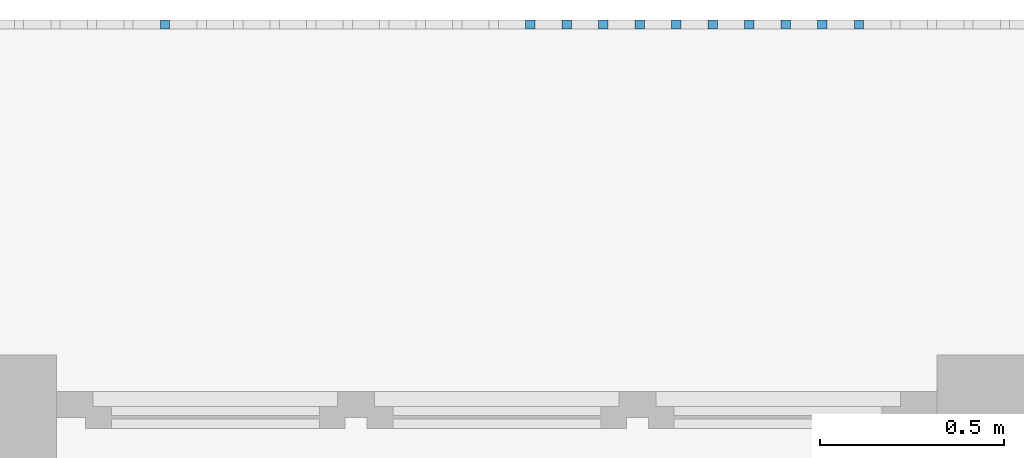
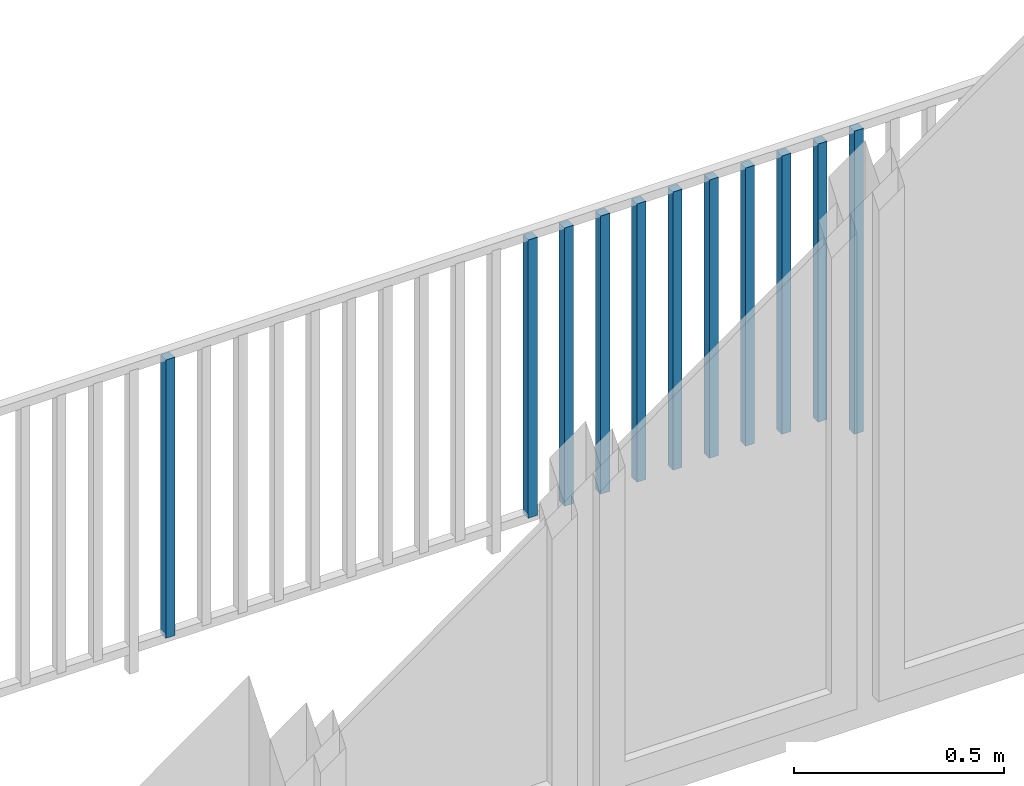
# One storey, part 51 of 54: 11 building element parts, 1 element without a shape of its own.
"""IFC4 building model written with IfcOpenShell, lengths in metres."""

from ifc_helpers import new_model, entity, si_unit, converted_unit, derived_unit, direction, frame, origin_with_axes, place, context, subcontext, project, spatial, polygons, material, type_object, element, aggregate, save


model = new_model("IFC4")

# Units and contexts
model_context = context("Model", 3, precision=1e-05, world=origin_with_axes(), true_north=direction((0.0, 1.0)))
body_context = subcontext(model_context, "Body", "Model", "MODEL_VIEW")
ifc_project = project(units=[si_unit("LENGTHUNIT", "METRE"), si_unit("AREAUNIT", "SQUARE_METRE"), si_unit("VOLUMEUNIT", "CUBIC_METRE"), converted_unit("PLANEANGLEUNIT", "DEGREE", entity("IfcPlaneAngleMeasure", 0.0174532925199), si_unit("PLANEANGLEUNIT", "RADIAN"), dimensions=[0, 0, 0, 0, 0, 0, 0]), converted_unit("TIMEUNIT", "Year", entity("IfcTimeMeasure", 31556926.0), si_unit("TIMEUNIT", "SECOND"), dimensions=[0, 0, 1, 0, 0, 0, 0]), si_unit("MASSUNIT", "GRAM", prefix="KILO"), si_unit("THERMODYNAMICTEMPERATUREUNIT", "DEGREE_CELSIUS"), si_unit("LUMINOUSINTENSITYUNIT", "LUMEN"), si_unit("ENERGYUNIT", "JOULE", prefix="MEGA"), derived_unit("THERMALCONDUCTANCEUNIT", [(si_unit("POWERUNIT", "WATT"), 1), (si_unit("LENGTHUNIT", "METRE"), -1), (si_unit("THERMODYNAMICTEMPERATUREUNIT", "KELVIN"), -1)]), derived_unit("SPECIFICHEATCAPACITYUNIT", [(si_unit("ENERGYUNIT", "JOULE"), 1), (si_unit("MASSUNIT", "GRAM", prefix="KILO"), -1), (si_unit("THERMODYNAMICTEMPERATUREUNIT", "KELVIN"), -1)]), derived_unit("MASSDENSITYUNIT", [(si_unit("MASSUNIT", "GRAM", prefix="KILO"), 1), (si_unit("VOLUMEUNIT", "CUBIC_METRE"), -1)])], contexts=[model_context])

# Site, building, storey, space
site_placement = place(None, origin_with_axes())
site = spatial("IfcSite", under=ifc_project, at=site_placement, CompositionType="ELEMENT")
building_placement = place(site_placement, origin_with_axes())
building = spatial("IfcBuilding", under=site, at=building_placement, CompositionType="ELEMENT")
storey_placement = place(building_placement, frame((0.0, 0.0, 9.18), z_axis=(0.0, 0.0, 1.0), x_axis=(1.0, 0.0, 0.0)))
storey = spatial("IfcBuildingStorey", under=building, at=storey_placement, Name="3. Geschoss", CompositionType="ELEMENT", Elevation=9.18)
space_placement = place(storey_placement, frame((10.2378006196, 9.82118769833, 0.0), z_axis=(0.0, 0.0, 1.0), x_axis=(-1.0, 0.0, 0.0)))
space = spatial("IfcSpace", under=storey, at=space_placement, CompositionType="ELEMENT", PredefinedType="EXTERNAL")

# Railing, building element parts
railing_type = type_object("IfcRailingType", PredefinedType="NOTDEFINED")
railing_placement = place(space_placement, frame((0.0, -7.06315681498e-08, 0.0), z_axis=(0.0, 0.0, 1.0), x_axis=(-1.0, 0.0, 0.0)))
railing = element("IfcRailing", 1, at=railing_placement, inside=space, type_object=railing_type, PredefinedType="NOTDEFINED")
ifc_material = material()
building_element_part_1_placement = place(railing_placement, origin_with_axes())
building_element_part_1 = element("IfcBuildingElementPart", 2, at=building_element_part_1_placement, material=ifc_material, PredefinedType="NOTDEFINED", context=body_context, shape_type="Tessellation", body=[
    polygons([(-6.97597826087, 0.0125, 0.0), (-6.97597826087, -0.0125, 0.0), (-6.97597826087, -0.0125, 0.88), (-6.97597826087, 0.0125, 0.88), (-6.95097826087, 0.0125, 0.0), (-6.95097826087, -0.0125, 0.0), (-6.95097826087, -0.0125, 0.88), (-6.95097826087, 0.0125, 0.88)], [[[1, 2, 3, 4]], [[1, 5, 6, 2]], [[2, 6, 7, 3]], [[4, 3, 7, 8]], [[5, 1, 4, 8]], [[6, 5, 8, 7]]], closed=True),
])
building_element_part_2_placement = place(railing_placement, origin_with_axes())
building_element_part_2 = element("IfcBuildingElementPart", 3, at=building_element_part_2_placement, material=ifc_material, PredefinedType="NOTDEFINED", context=body_context, shape_type="Tessellation", body=[
    polygons([(-7.07545652174, 0.0125, 0.07), (-7.07545652174, -0.0125, 0.07), (-7.07545652174, -0.0125, 0.8775), (-7.07545652174, 0.0125, 0.8775), (-7.05045652174, 0.0125, 0.07), (-7.05045652174, -0.0125, 0.07), (-7.05045652174, -0.0125, 0.8775), (-7.05045652174, 0.0125, 0.8775)], [[[1, 2, 3, 4]], [[1, 5, 6, 2]], [[2, 6, 7, 3]], [[4, 3, 7, 8]], [[5, 1, 4, 8]], [[6, 5, 8, 7]]], closed=True),
])
building_element_part_3_placement = place(railing_placement, origin_with_axes())
building_element_part_3 = element("IfcBuildingElementPart", 4, at=building_element_part_3_placement, material=ifc_material, PredefinedType="NOTDEFINED", context=body_context, shape_type="Tessellation", body=[
    polygons([(-7.17493478261, 0.0125, 0.07), (-7.17493478261, -0.0125, 0.07), (-7.17493478261, -0.0125, 0.8775), (-7.17493478261, 0.0125, 0.8775), (-7.14993478261, 0.0125, 0.07), (-7.14993478261, -0.0125, 0.07), (-7.14993478261, -0.0125, 0.8775), (-7.14993478261, 0.0125, 0.8775)], [[[1, 2, 3, 4]], [[1, 5, 6, 2]], [[2, 6, 7, 3]], [[4, 3, 7, 8]], [[5, 1, 4, 8]], [[6, 5, 8, 7]]], closed=True),
])
building_element_part_4_placement = place(railing_placement, origin_with_axes())
building_element_part_4 = element("IfcBuildingElementPart", 5, at=building_element_part_4_placement, material=ifc_material, PredefinedType="NOTDEFINED", context=body_context, shape_type="Tessellation", body=[
    polygons([(-7.27441304348, 0.0125, 0.07), (-7.27441304348, -0.0125, 0.07), (-7.27441304348, -0.0125, 0.8775), (-7.27441304348, 0.0125, 0.8775), (-7.24941304348, 0.0125, 0.07), (-7.24941304348, -0.0125, 0.07), (-7.24941304348, -0.0125, 0.8775), (-7.24941304348, 0.0125, 0.8775)], [[[1, 2, 3, 4]], [[1, 5, 6, 2]], [[2, 6, 7, 3]], [[4, 3, 7, 8]], [[5, 1, 4, 8]], [[6, 5, 8, 7]]], closed=True),
])
building_element_part_5_placement = place(railing_placement, origin_with_axes())
building_element_part_5 = element("IfcBuildingElementPart", 6, at=building_element_part_5_placement, material=ifc_material, PredefinedType="NOTDEFINED", context=body_context, shape_type="Tessellation", body=[
    polygons([(-7.37389130435, 0.0125, 0.07), (-7.37389130435, -0.0125, 0.07), (-7.37389130435, -0.0125, 0.8775), (-7.37389130435, 0.0125, 0.8775), (-7.34889130435, 0.0125, 0.07), (-7.34889130435, -0.0125, 0.07), (-7.34889130435, -0.0125, 0.8775), (-7.34889130435, 0.0125, 0.8775)], [[[1, 2, 3, 4]], [[1, 5, 6, 2]], [[2, 6, 7, 3]], [[4, 3, 7, 8]], [[5, 1, 4, 8]], [[6, 5, 8, 7]]], closed=True),
])
building_element_part_6_placement = place(railing_placement, origin_with_axes())
building_element_part_6 = element("IfcBuildingElementPart", 7, at=building_element_part_6_placement, material=ifc_material, PredefinedType="NOTDEFINED", context=body_context, shape_type="Tessellation", body=[
    polygons([(-7.47336956522, 0.0125, 0.07), (-7.47336956522, -0.0125, 0.07), (-7.47336956522, -0.0125, 0.8775), (-7.47336956522, 0.0125, 0.8775), (-7.44836956522, 0.0125, 0.07), (-7.44836956522, -0.0125, 0.07), (-7.44836956522, -0.0125, 0.8775), (-7.44836956522, 0.0125, 0.8775)], [[[1, 2, 3, 4]], [[1, 5, 6, 2]], [[2, 6, 7, 3]], [[4, 3, 7, 8]], [[5, 1, 4, 8]], [[6, 5, 8, 7]]], closed=True),
])
building_element_part_7_placement = place(railing_placement, origin_with_axes())
building_element_part_7 = element("IfcBuildingElementPart", 8, at=building_element_part_7_placement, material=ifc_material, PredefinedType="NOTDEFINED", context=body_context, shape_type="Tessellation", body=[
    polygons([(-7.57284782609, 0.0125, 0.07), (-7.57284782609, -0.0125, 0.07), (-7.57284782609, -0.0125, 0.8775), (-7.57284782609, 0.0125, 0.8775), (-7.54784782609, 0.0125, 0.07), (-7.54784782609, -0.0125, 0.07), (-7.54784782609, -0.0125, 0.8775), (-7.54784782609, 0.0125, 0.8775)], [[[1, 2, 3, 4]], [[1, 5, 6, 2]], [[2, 6, 7, 3]], [[4, 3, 7, 8]], [[5, 1, 4, 8]], [[6, 5, 8, 7]]], closed=True),
])
building_element_part_8_placement = place(railing_placement, origin_with_axes())
building_element_part_8 = element("IfcBuildingElementPart", 9, at=building_element_part_8_placement, material=ifc_material, PredefinedType="NOTDEFINED", context=body_context, shape_type="Tessellation", body=[
    polygons([(-7.67232608696, 0.0125, 0.07), (-7.67232608696, -0.0125, 0.07), (-7.67232608696, -0.0125, 0.8775), (-7.67232608696, 0.0125, 0.8775), (-7.64732608696, 0.0125, 0.07), (-7.64732608696, -0.0125, 0.07), (-7.64732608696, -0.0125, 0.8775), (-7.64732608696, 0.0125, 0.8775)], [[[1, 2, 3, 4]], [[1, 5, 6, 2]], [[2, 6, 7, 3]], [[4, 3, 7, 8]], [[5, 1, 4, 8]], [[6, 5, 8, 7]]], closed=True),
])
building_element_part_9_placement = place(railing_placement, origin_with_axes())
building_element_part_9 = element("IfcBuildingElementPart", 10, at=building_element_part_9_placement, material=ifc_material, PredefinedType="NOTDEFINED", context=body_context, shape_type="Tessellation", body=[
    polygons([(-7.77180434783, 0.0125, 0.07), (-7.77180434783, -0.0125, 0.07), (-7.77180434783, -0.0125, 0.8775), (-7.77180434783, 0.0125, 0.8775), (-7.74680434783, 0.0125, 0.07), (-7.74680434783, -0.0125, 0.07), (-7.74680434783, -0.0125, 0.8775), (-7.74680434783, 0.0125, 0.8775)], [[[1, 2, 3, 4]], [[1, 5, 6, 2]], [[2, 6, 7, 3]], [[4, 3, 7, 8]], [[5, 1, 4, 8]], [[6, 5, 8, 7]]], closed=True),
])
building_element_part_10_placement = place(railing_placement, origin_with_axes())
building_element_part_10 = element("IfcBuildingElementPart", 11, at=building_element_part_10_placement, material=ifc_material, PredefinedType="NOTDEFINED", context=body_context, shape_type="Tessellation", body=[
    polygons([(-7.8712826087, 0.0125, 0.07), (-7.8712826087, -0.0125, 0.07), (-7.8712826087, -0.0125, 0.8775), (-7.8712826087, 0.0125, 0.8775), (-7.8462826087, 0.0125, 0.07), (-7.8462826087, -0.0125, 0.07), (-7.8462826087, -0.0125, 0.8775), (-7.8462826087, 0.0125, 0.8775)], [[[1, 2, 3, 4]], [[1, 5, 6, 2]], [[2, 6, 7, 3]], [[4, 3, 7, 8]], [[5, 1, 4, 8]], [[6, 5, 8, 7]]], closed=True),
])
building_element_part_11_placement = place(railing_placement, origin_with_axes())
building_element_part_11 = element("IfcBuildingElementPart", 12, at=building_element_part_11_placement, material=ifc_material, PredefinedType="NOTDEFINED", context=body_context, shape_type="Tessellation", body=[
    polygons([(-8.86606521739, 0.0125, 0.07), (-8.86606521739, -0.0125, 0.07), (-8.86606521739, -0.0125, 0.8775), (-8.86606521739, 0.0125, 0.8775), (-8.84106521739, 0.0125, 0.07), (-8.84106521739, -0.0125, 0.07), (-8.84106521739, -0.0125, 0.8775), (-8.84106521739, 0.0125, 0.8775)], [[[1, 2, 3, 4]], [[1, 5, 6, 2]], [[2, 6, 7, 3]], [[4, 3, 7, 8]], [[5, 1, 4, 8]], [[6, 5, 8, 7]]], closed=True),
])
aggregate(railing, [building_element_part_1, building_element_part_2, building_element_part_3, building_element_part_4, building_element_part_5, building_element_part_6, building_element_part_7, building_element_part_8, building_element_part_9, building_element_part_10, building_element_part_11])

save(model, "model.ifc")
